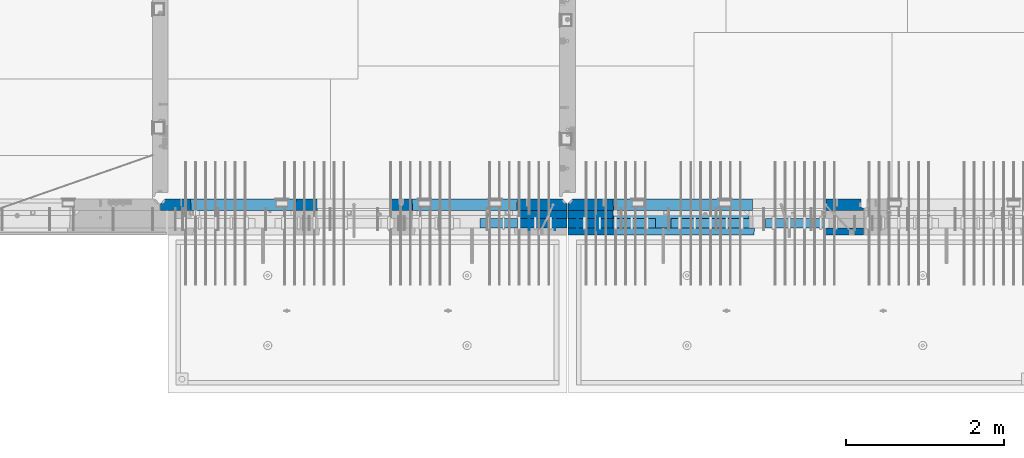
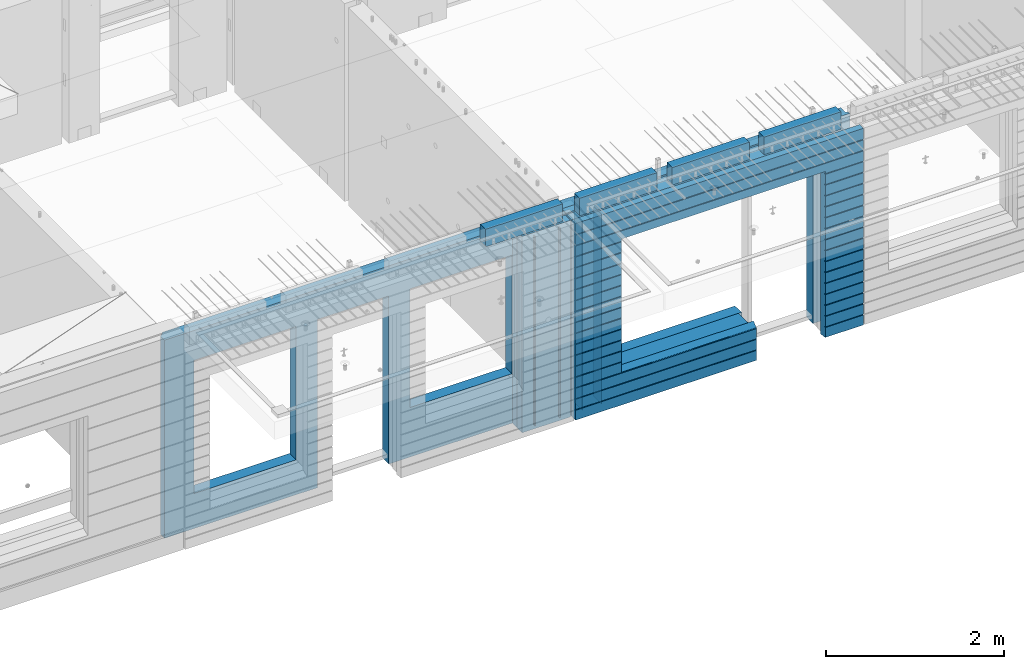
# One storey, part 232 of 350: 16 walls, 8 elements without a shape of their own.
"""IFC2X3 building model written with IfcOpenShell, lengths in millimetres."""

from ifc_helpers import new_model, si_unit, frame, origin_with_axes, place, context, subcontext, project, spatial, faceted_brep, material, type_object, element, aggregate, save


model = new_model("IFC2X3")

# Units and contexts
model_context = context("Model", 3, precision=1e-05, world=origin_with_axes())
body_context = subcontext(model_context, "Body", "Model", "MODEL_VIEW")
ifc_project = project(units=[si_unit("LENGTHUNIT", "METRE", prefix="MILLI"), si_unit("AREAUNIT", "SQUARE_METRE"), si_unit("VOLUMEUNIT", "CUBIC_METRE"), si_unit("MASSUNIT", "GRAM", prefix="KILO"), si_unit("TIMEUNIT", "SECOND"), si_unit("PLANEANGLEUNIT", "RADIAN"), si_unit("SOLIDANGLEUNIT", "STERADIAN"), si_unit("THERMODYNAMICTEMPERATUREUNIT", "DEGREE_CELSIUS"), si_unit("LUMINOUSINTENSITYUNIT", "LUMEN")], contexts=[model_context])

# Site, building, storey
site_placement = place(None, origin_with_axes())
site = spatial("IfcSite", under=ifc_project, at=site_placement, CompositionType="ELEMENT")
building_placement = place(site_placement, origin_with_axes())
building = spatial("IfcBuilding", under=site, at=building_placement, CompositionType="ELEMENT")
storey_placement = place(building_placement, origin_with_axes())
storey = spatial("IfcBuildingStorey", under=building, at=storey_placement, Name="2", CompositionType="ELEMENT", Elevation=0.0)

# Assembly, walls
assembly_1_placement = place(storey_placement, origin_with_axes())
assembly_1 = element("IfcElementAssembly", 1, at=assembly_1_placement, inside=storey, AssemblyPlace="NOTDEFINED", PredefinedType="REINFORCEMENT_UNIT")
ifc_material_1 = material(Name="Undefined")
wall_type_1 = type_object("IfcWallType", PredefinedType="NOTDEFINED")
wall_1_placement = place(assembly_1_placement, frame((21325.0, 7780.0, 86115.0), z_axis=(0.0, 0.0, 1.0), x_axis=(0.0, -1.0, 0.0)))
wall_1 = element("IfcWall", 2, at=wall_1_placement, type_object=wall_type_1, material=ifc_material_1, Name="(PD)", context=body_context, shape_type="Brep", body=[
    faceted_brep([(0.0, 5.0, -1300.0), (0.0, 5.0, 1300.0), (180.0, 5.0, 1300.0), (180.0, 5.0, -1300.0), (0.0, -5.0, 1300.0), (180.0, -5.0, 1300.0), (0.0, -5.0, -1300.0), (180.0, -5.0, -1300.0)], [[[0, 1, 2, 3]], [[1, 4, 5, 2]], [[4, 6, 7, 5]], [[6, 0, 3, 7]], [[5, 7, 3, 2]], [[6, 4, 1, 0]]]),
])
wall_2_placement = place(assembly_1_placement, frame((21650.0, 7780.0, 86115.0), z_axis=(0.0, 0.0, 1.0), x_axis=(0.0, -1.0, 0.0)))
wall_2 = element("IfcWall", 3, at=wall_2_placement, type_object=wall_type_1, material=ifc_material_1, Name="(PD)", context=body_context, shape_type="Brep", body=[
    faceted_brep([(0.0, 5.0, -1300.0), (0.0, 5.0, 1300.0), (180.0, 5.0, 1300.0), (180.0, 5.0, -1300.0), (0.0, -5.0, 1300.0), (180.0, -5.0, 1300.0), (0.0, -5.0, -1300.0), (180.0, -5.0, -1300.0)], [[[0, 1, 2, 3]], [[1, 4, 5, 2]], [[4, 6, 7, 5]], [[6, 0, 3, 7]], [[5, 7, 3, 2]], [[6, 4, 1, 0]]]),
])

assembly_2_placement = place(storey_placement, origin_with_axes())
assembly_2 = element("IfcElementAssembly", 4, at=assembly_2_placement, inside=storey, AssemblyPlace="NOTDEFINED", PredefinedType="REINFORCEMENT_UNIT")
wall_3_placement = place(assembly_2_placement, frame((22190.0, 7780.0, 86115.0), z_axis=(0.0, 0.0, 1.0), x_axis=(0.0, -1.0, 0.0)))
wall_3 = element("IfcWall", 5, at=wall_3_placement, type_object=wall_type_1, material=ifc_material_1, Name="(PD)", context=body_context, shape_type="Brep", body=[
    faceted_brep([(0.0, 5.0, -1300.0), (0.0, 5.0, 1300.0), (180.0, 5.0, 1300.0), (180.0, 5.0, -1300.0), (0.0, -5.0, 1300.0), (180.0, -5.0, 1300.0), (0.0, -5.0, -1300.0), (180.0, -5.0, -1300.0)], [[[0, 1, 2, 3]], [[1, 4, 5, 2]], [[4, 6, 7, 5]], [[6, 0, 3, 7]], [[5, 7, 3, 2]], [[6, 4, 1, 0]]]),
])
wall_4_placement = place(assembly_2_placement, frame((21940.0, 7780.0, 86115.0), z_axis=(0.0, 0.0, 1.0), x_axis=(0.0, -1.0, 0.0)))
wall_4 = element("IfcWall", 6, at=wall_4_placement, type_object=wall_type_1, material=ifc_material_1, Name="(PD)", context=body_context, shape_type="Brep", body=[
    faceted_brep([(0.0, 5.0, -1300.0), (0.0, 5.0, 1300.0), (180.0, 5.0, 1300.0), (180.0, 5.0, -1300.0), (0.0, -5.0, 1300.0), (180.0, -5.0, 1300.0), (0.0, -5.0, -1300.0), (180.0, -5.0, -1300.0)], [[[0, 1, 2, 3]], [[1, 4, 5, 2]], [[4, 6, 7, 5]], [[6, 0, 3, 7]], [[5, 7, 3, 2]], [[6, 4, 1, 0]]]),
])

# Assemblies, wall
assembly_3_placement = place(storey_placement, origin_with_axes())
assembly_3 = element("IfcElementAssembly", 7, at=assembly_3_placement, inside=storey, AssemblyPlace="NOTDEFINED", PredefinedType="REINFORCEMENT_UNIT")
assembly_4_placement = place(assembly_3_placement, origin_with_axes())
assembly_4 = element("IfcElementAssembly", 8, at=assembly_4_placement, Name="Steel Assembly", AssemblyPlace="NOTDEFINED", PredefinedType="NOTDEFINED")
aggregate(assembly_3, [assembly_4])
ifc_material_2 = material()
wall_type_2 = type_object("IfcWallType", PredefinedType="NOTDEFINED")
wall_5_placement = place(assembly_4_placement, frame((20699.9998568133, 7690.00021946163, 87590.0), z_axis=(0.0, 0.0, 1.0), x_axis=(1.0, 0.0, 0.0)))
wall_5 = element("IfcWall", 9, at=wall_5_placement, type_object=wall_type_2, material=ifc_material_2, context=body_context, shape_type="Brep", body=[
    faceted_brep([(0.0, 60.0, -120.0), (0.0, 60.0, 120.0), (1000.0, 60.0, 120.0), (1000.0, 60.0, -120.0), (0.0, -60.0, 120.0), (1000.0, -60.0, 120.0), (0.0, -60.0, -120.0), (1000.0, -60.0, -120.0)], [[[0, 1, 2, 3]], [[1, 4, 5, 2]], [[4, 6, 7, 5]], [[6, 0, 3, 7]], [[5, 7, 3, 2]], [[6, 4, 1, 0]]]),
])
aggregate(assembly_4, [wall_5])

# Assemblies, walls
assembly_5_placement = place(storey_placement, origin_with_axes())
assembly_5 = element("IfcElementAssembly", 10, at=assembly_5_placement, inside=storey, AssemblyPlace="NOTDEFINED", PredefinedType="REINFORCEMENT_UNIT")
assembly_6_placement = place(assembly_5_placement, origin_with_axes())
assembly_6 = element("IfcElementAssembly", 11, at=assembly_6_placement, Name="Steel Assembly", AssemblyPlace="NOTDEFINED", PredefinedType="NOTDEFINED")
wall_6_placement = place(assembly_6_placement, frame((24309.9998568133, 7690.00021946163, 87590.0), z_axis=(0.0, 0.0, 1.0), x_axis=(1.0, 0.0, 0.0)))
wall_6 = element("IfcWall", 12, at=wall_6_placement, type_object=wall_type_2, material=ifc_material_2, context=body_context, shape_type="Brep", body=[
    faceted_brep([(0.0, 60.0, -120.0), (0.0, 60.0, 120.0), (1000.0, 60.0, 120.0), (1000.0, 60.0, -120.0), (0.0, -60.0, 120.0), (1000.0, -60.0, 120.0), (0.0, -60.0, -120.0), (1000.0, -60.0, -120.0)], [[[0, 1, 2, 3]], [[1, 4, 5, 2]], [[4, 6, 7, 5]], [[6, 0, 3, 7]], [[5, 7, 3, 2]], [[6, 4, 1, 0]]]),
])
aggregate(assembly_6, [wall_6])
assembly_7_placement = place(assembly_5_placement, origin_with_axes())
assembly_7 = element("IfcElementAssembly", 13, at=assembly_7_placement, Name="Steel Assembly", AssemblyPlace="NOTDEFINED", PredefinedType="NOTDEFINED")
wall_7_placement = place(assembly_7_placement, frame((23119.9998568133, 7690.00021946163, 87590.0), z_axis=(0.0, 0.0, 1.0), x_axis=(1.0, 0.0, 0.0)))
wall_7 = element("IfcWall", 14, at=wall_7_placement, type_object=wall_type_2, material=ifc_material_2, context=body_context, shape_type="Brep", body=[
    faceted_brep([(0.0, 60.0, -120.0), (0.0, 60.0, 120.0), (1000.0, 60.0, 120.0), (1000.0, 60.0, -120.0), (0.0, -60.0, 120.0), (1000.0, -60.0, 120.0), (0.0, -60.0, -120.0), (1000.0, -60.0, -120.0)], [[[0, 1, 2, 3]], [[1, 4, 5, 2]], [[4, 6, 7, 5]], [[6, 0, 3, 7]], [[5, 7, 3, 2]], [[6, 4, 1, 0]]]),
])
aggregate(assembly_7, [wall_7])
assembly_8_placement = place(assembly_5_placement, origin_with_axes())
assembly_8 = element("IfcElementAssembly", 15, at=assembly_8_placement, Name="Steel Assembly", AssemblyPlace="NOTDEFINED", PredefinedType="NOTDEFINED")
aggregate(assembly_5, [assembly_8, assembly_7, assembly_6])
wall_8_placement = place(assembly_8_placement, frame((21919.9998568133, 7690.00021946163, 87590.0), z_axis=(0.0, 0.0, 1.0), x_axis=(1.0, 0.0, 0.0)))
wall_8 = element("IfcWall", 16, at=wall_8_placement, type_object=wall_type_2, material=ifc_material_2, context=body_context, shape_type="Brep", body=[
    faceted_brep([(0.0, 60.0, -120.0), (0.0, 60.0, 120.0), (1000.0, 60.0, 120.0), (1000.0, 60.0, -120.0), (0.0, -60.0, 120.0), (1000.0, -60.0, 120.0), (0.0, -60.0, -120.0), (1000.0, -60.0, -120.0)], [[[0, 1, 2, 3]], [[1, 4, 5, 2]], [[4, 6, 7, 5]], [[6, 0, 3, 7]], [[5, 7, 3, 2]], [[6, 4, 1, 0]]]),
])
aggregate(assembly_8, [wall_8])

# Wall
ifc_material_3 = material(Name="CONCRETE/C35/45")
wall_type_3 = type_object("IfcWallType", PredefinedType="NOTDEFINED")
wall_9_placement = place(assembly_1_placement, frame((21810.0, 7925.0, 86112.5), z_axis=(0.0, 0.0, 1.0), x_axis=(-1.0, 3.00000001838171e-08, 0.0)))
wall_9 = element("IfcWall", 17, at=wall_9_placement, type_object=wall_type_3, material=ifc_material_3, context=body_context, shape_type="Brep", body=[
    faceted_brep([(5145.0, 75.0, -1357.5), (5145.0, -15.0, -1357.5), (5085.0, -75.0, -1357.5), (3165.00051719707, -75.0, -1357.5), (3161.15436335092, 75.0, -1357.5), (5085.0, -75.0, 1357.5), (5145.0, -15.0, 1357.5), (5145.0, 75.0, 1357.5), (10.0, 75.0, 1357.5), (10.0, -15.0, 1357.5), (70.0, -75.0, 1357.5), (10.0, -15.0, -1357.5), (70.0, -75.0, -1357.5), (10.0, 75.0, -1357.5), (2238.84667104322, 75.0, -1357.5), (2235.00051719707, -75.0, -1357.5), (2238.84667104322, 75.0, 948.653846153844), (2235.00051719707, -75.0, 952.5), (635.00013572734, -75.0, -682.5), (639.054189781393, 75.0, -678.445945945947), (639.054189781393, 75.0, 948.445945945947), (635.00013572734, -75.0, 952.5), (1965.00013572734, -75.0, -682.5), (1960.94608167329, 75.0, -678.445945945947), (1965.00013572734, -75.0, 952.5), (1960.94608167329, 75.0, 948.445945945947), (4764.99937278789, -75.0, -882.5), (4760.94531873383, 75.0, -878.445945945947), (3439.05342684194, 75.0, -878.445945945947), (3434.99937278789, -75.0, -882.5), (3165.00051719707, -75.0, 952.5), (3434.99937278789, -75.0, 952.5), (4764.99937278789, -75.0, 952.5), (4760.94531873383, 75.0, 948.445945945947), (3439.05342684194, 75.0, 948.445945945947), (3161.15436335092, 75.0, 948.653846153844)], [[[0, 1, 2, 3, 4]], [[5, 2, 1, 6]], [[0, 7, 6, 1]], [[5, 6, 7, 8, 9, 10]], [[9, 11, 12, 10]], [[8, 13, 11, 9]], [[12, 11, 13, 14, 15]], [[15, 14, 16, 17]], [[18, 19, 20, 21]], [[22, 23, 19, 18]], [[23, 22, 24, 25]], [[21, 20, 25, 24]], [[26, 27, 28, 29]], [[3, 2, 5, 10, 12, 15, 17, 30], [26, 29, 31, 32], [22, 18, 21, 24]], [[27, 26, 32, 33]], [[31, 34, 33, 32]], [[29, 28, 34, 31]], [[13, 8, 7, 0, 4, 35, 16, 14], [27, 33, 34, 28], [23, 25, 20, 19]], [[17, 16, 35, 30]], [[4, 3, 30, 35]]]),
])

wall_10_placement = place(assembly_2_placement, frame((25550.0, 7925.0, 86112.5), z_axis=(0.0, 0.0, 1.0), x_axis=(-1.0, 3.00000001838171e-08, 0.0)))
wall_10 = element("IfcWall", 18, at=wall_10_placement, type_object=wall_type_3, material=ifc_material_3, context=body_context, shape_type="Brep", body=[
    faceted_brep([(0.0, 75.0, 1357.5), (0.0, 75.0, -1357.5), (0.0, 45.0, -1357.5), (0.0, 45.0, 1357.5), (475.000517197066, -75.0, -1357.5), (478.846671043222, 75.0, -1357.5), (478.846671043219, 75.0, 948.653846153844), (475.000517197066, -75.0, 952.5), (32.5, -75.0, -1357.5), (32.5, 32.0, -1357.5), (32.5, -75.0, 1357.5), (32.5, 32.0, 1357.5), (3675.0, -75.0, 1357.5), (3735.0, -15.0, 1357.5), (3735.0, 75.0, 1357.5), (3735.0, 75.0, -1357.5), (3735.0, -15.0, -1357.5), (3675.0, -75.0, -1357.5), (1405.00051719707, -75.0, -1357.5), (1401.15436335091, 75.0, -1357.5), (1405.00051719707, -75.0, -882.5), (1401.15436335091, 75.0, -878.445945945947), (1334.05403802673, 75.0, 948.653846153844), (3160.9460816706, 75.0, -878.445945945947), (3160.9460816706, 75.0, 948.445945945947), (1401.15436335091, 75.0, 948.653846153844), (1330.00013572465, -75.0, 952.5), (1405.00051719707, -75.0, 952.5), (3165.00013572465, -75.0, -882.5), (3165.00013572465, -75.0, 952.5)], [[[0, 1, 2, 3]], [[4, 5, 6, 7]], [[8, 9, 2, 1, 5, 4]], [[10, 11, 9, 8]], [[3, 2, 9, 11]], [[10, 12, 13, 14, 0, 3, 11]], [[15, 14, 13, 16]], [[12, 17, 16, 13]], [[15, 16, 17, 18, 19]], [[19, 18, 20, 21]], [[22, 6, 5, 1, 0, 14, 15, 19, 21, 23, 24, 25]], [[26, 7, 6, 22, 25, 27]], [[28, 20, 18, 17, 12, 10, 8, 4, 7, 26, 27, 29]], [[25, 24, 29, 27]], [[23, 28, 29, 24]], [[21, 20, 28, 23]]]),
])

wall_type_4 = type_object("IfcWallType", PredefinedType="NOTDEFINED")
wall_11_placement = place(assembly_1_placement, frame((21800.0000381475, 7800.0, 86112.5), z_axis=(0.0, 0.0, 1.0), x_axis=(-1.0, 3.00000001838171e-08, 0.0)))
wall_11 = element("IfcWall", 19, at=wall_11_placement, type_object=wall_type_4, material=ifc_material_3, context=body_context, shape_type="Brep", body=[
    faceted_brep([(0.0, 50.0, -1357.5), (0.0, 50.0, 1357.5), (625.001908754726, 50.0, 1357.5), (625.001908754726, 50.0, -1357.5), (0.0, -50.0, 1357.5), (625.001908754726, -50.0, 1357.5), (0.0, -50.0, -1357.5), (625.001908754726, -50.0, -1357.5)], [[[0, 1, 2, 3]], [[1, 4, 5, 2]], [[4, 6, 7, 5]], [[6, 0, 3, 7]], [[5, 7, 3, 2]], [[6, 4, 1, 0]]]),
])

wall_12_placement = place(assembly_2_placement, frame((22385.0000381475, 7800.00011629906, 86112.5), z_axis=(0.0, 0.0, 1.0), x_axis=(-1.0, 3.00000001838171e-08, 0.0)))
wall_12 = element("IfcWall", 20, at=wall_12_placement, type_object=wall_type_4, material=ifc_material_3, context=body_context, shape_type="Brep", body=[
    faceted_brep([(0.0, 50.0, -1357.5), (0.0, 50.0, 1357.5), (570.001908754726, 50.0, 1357.5), (570.001908754726, 50.0, -1357.5), (0.0, -50.0, 1357.5), (570.001908754726, -50.0, 1357.5), (0.0, -50.0, -1357.5), (570.001908754726, -50.0, -1357.5)], [[[0, 1, 2, 3]], [[1, 4, 5, 2]], [[4, 6, 7, 5]], [[6, 0, 3, 7]], [[5, 7, 3, 2]], [[6, 4, 1, 0]]]),
])

ifc_material_4 = material(Name="SPU")
wall_type_5 = type_object("IfcWallType", PredefinedType="NOTDEFINED")
wall_13_placement = place(assembly_1_placement, frame((21800.0000381475, 7690.0, 86102.5), z_axis=(0.0, 0.0, 1.0), x_axis=(-1.0, 3.00000001838171e-08, 0.0)))
wall_13 = element("IfcWall", 21, at=wall_13_placement, type_object=wall_type_5, material=ifc_material_4, context=body_context, shape_type="Brep", body=[
    faceted_brep([(0.0, 60.0, -1347.5), (0.0, 60.0, 1347.5), (625.001908754726, 60.0, 1347.5), (625.001908754726, 60.0, -1347.5), (0.0, -60.0, 1347.5), (625.001908754726, -60.0, 1347.5), (0.0, -60.0, -1347.5), (625.001908754726, -60.0, -1347.5)], [[[0, 1, 2, 3]], [[1, 4, 5, 2]], [[4, 6, 7, 5]], [[6, 0, 3, 7]], [[5, 7, 3, 2]], [[6, 4, 1, 0]]]),
])

aggregate(assembly_1, [wall_13, wall_11, wall_1, wall_2, wall_9])

wall_14_placement = place(assembly_2_placement, frame((22385.0000381475, 7690.00011629906, 86102.5), z_axis=(0.0, 0.0, 1.0), x_axis=(-1.0, 3.00000001838171e-08, 0.0)))
wall_14 = element("IfcWall", 22, at=wall_14_placement, type_object=wall_type_5, material=ifc_material_4, context=body_context, shape_type="Brep", body=[
    faceted_brep([(0.0, 60.0, -1347.5), (0.0, 60.0, 1347.5), (570.001908754726, 60.0, 1347.5), (570.001908754726, 60.0, -1347.5), (0.0, -60.0, 1347.5), (570.001908754726, -60.0, 1347.5), (0.0, -60.0, -1347.5), (570.001908754726, -60.0, -1347.5)], [[[0, 1, 2, 3]], [[1, 4, 5, 2]], [[4, 6, 7, 5]], [[6, 0, 3, 7]], [[5, 7, 3, 2]], [[6, 4, 1, 0]]]),
])

ifc_material_5 = material(Name="CONCRETE/C30/37")
wall_type_6 = type_object("IfcWallType", PredefinedType="NOTDEFINED")
wall_15_placement = place(assembly_2_placement, frame((25550.0, 7587.5, 86102.5), z_axis=(0.0, 0.0, 1.0), x_axis=(-1.0, 3.00000001838171e-08, 0.0)))
wall_15 = element("IfcWall", 23, at=wall_15_placement, type_object=wall_type_6, material=ifc_material_5, context=body_context, shape_type="Brep", body=[
    faceted_brep([(3135.00013572465, 42.5, -912.000000055254), (3135.00013572465, 42.5, -912.5), (3134.8486205936, 41.2121213860491, -911.742424344731), (3735.0, 32.4999991126861, -1049.99999959956), (3735.0, 32.4999992506973, -1060.00000000076), (1383.82179161871, 32.4999992506973, -1060.00000000076), (1383.82179160247, 32.4999991126861, -1049.99999959956), (3735.0, 42.5, -1062.00000005522), (1384.99845837354, 42.5, -1062.00000005522), (3735.0, 42.5, -1198.00000011075), (1384.99845837354, 42.5, -1198.00000011075), (3735.0, 32.4999991121604, -1199.99999959957), (1383.8217916024, 32.4999991121604, -1199.99999959957), (3735.0, 32.4999992501671, -1210.00000000079), (1383.82179161864, 32.4999992501671, -1210.00000000079), (3735.0, 42.5, -1212.00000005524), (1384.99845837354, 42.5, -1212.00000005524), (3735.0, 42.5, -1347.5), (1384.99845837354, 42.5, -1347.5), (3735.0, -42.5, -1347.5), (1374.99679170687, -42.5, -1347.5), (3.63797880709171e-12, 32.4999992499725, 1039.99999999921), (3735.0, 32.4999992499725, 1039.99999999921), (3735.0, 42.5, 1037.99999994476), (0.0, 42.5, 1037.99999994476), (3.63797880709171e-12, 32.4999991119639, 1050.00000040043), (3735.0, 32.4999991119639, 1050.00000040043), (0.0, 42.5, 1051.99999988925), (3735.0, 42.5, 1051.99999988925), (0.0, 42.5, 1187.99999994476), (3735.0, 42.5, 1187.99999994476), (-3.63797880709171e-12, 32.499999249967, 1189.99999999923), (3735.0, 32.499999249967, 1189.99999999923), (-3.63797880709171e-12, 32.4999991119576, 1200.00000040043), (3735.0, 32.4999991119576, 1200.00000040043), (0.0, 42.5, 1201.99999988925), (3735.0, 42.5, 1201.99999988925), (0.0, 42.5, 1347.5), (3735.0, 42.5, 1347.5), (0.0, -42.5, 1347.5), (3735.0, -42.5, 1347.5), (3125.00013572465, -42.5, 927.5), (3125.00013572465, -42.5, -862.5), (1374.99679170687, -42.5, -862.5), (0.0, -42.5, -1347.5), (505.000125040202, -42.5, -1347.5), (505.000125040206, -42.5, 927.5), (505.000125040206, -42.5, 932.502857142856), (1370.00013572465, -42.5, 932.502857142856), (1374.99679170687, -42.5, 932.5), (3125.00013572465, -42.5, 932.5), (0.0, 42.5, -1347.5), (494.998458373539, 42.5, -1347.5), (0.0, 42.5, -1212.00000005524), (494.998458373539, 42.5, -1212.00000005524), (0.0, 32.4999992501671, -1210.00000000079), (496.175125128437, 32.4999992501671, -1210.00000000079), (0.0, 32.4999991121604, -1199.99999959957), (496.175125144673, 32.4999991121604, -1199.99999959957), (0.0, 42.5, -1198.00000011075), (494.998458373539, 42.5, -1198.00000011075), (0.0, 42.5, -1062.00000005522), (494.998458373539, 42.5, -1062.00000005522), (0.0, 32.4999992506973, -1060.00000000076), (496.175125128375, 32.4999992506973, -1060.00000000076), (0.0, 32.4999991126861, -1049.99999959956), (496.175125144611, 32.4999991126861, -1049.99999959956), (0.0, 42.5, -1048.00000011074), (494.998458373539, 42.5, -1048.00000011074), (0.0, 42.5, -912.000000055254), (494.998458373539, 42.5, -912.000000055254), (0.0, 32.4999992512376, -910.000000000786), (496.175125128309, 32.4999992512376, -910.000000000786), (0.0, 32.499999113239, -899.99999959959), (496.175125144546, 32.499999113239, -899.99999959959), (0.0, 42.5, -898.000000110769), (494.998458373539, 42.5, -898.000000110769), (0.0, 42.5, -762.000000055225), (494.998458373539, 42.5, -762.000000055225), (0.0, 32.4999992517696, -760.000000000757), (496.175125128244, 32.4999992517696, -760.000000000757), (0.0, 32.4999991137702, -749.99999959956), (496.175125144484, 32.4999991137702, -749.99999959956), (0.0, 42.5, -748.00000011074), (494.998458373539, 42.5, -748.00000011074), (0.0, 42.5, -612.000000055239), (494.998458373539, 42.5, -612.000000055239), (0.0, 32.4999992522971, -610.000000000771), (496.175125128182, 32.4999992522971, -610.000000000771), (0.0, 32.4999991143004, -599.99999959956), (496.175125144422, 32.4999991143004, -599.99999959956), (0.0, 42.5, -598.000000110755), (494.998458373539, 42.5, -598.000000110755), (0.0, 42.5, -462.000000055239), (494.998458373539, 42.5, -462.000000055239), (0.0, 32.4999992528365, -460.000000000771), (496.17512512812, 32.4999992528365, -460.000000000771), (0.0, 32.4999991148252, -449.999999599575), (496.17512514436, 32.4999991148252, -449.999999599575), (0.0, 42.5, -448.000000110755), (494.998458373539, 42.5, -448.000000110755), (0.0, 42.5, -312.000000055254), (494.998458373539, 42.5, -312.000000055254), (0.0, 32.4999992533649, -310.000000000786), (496.175125128058, 32.4999992533649, -310.000000000786), (0.0, 32.4999991153618, -299.99999959959), (496.175125144298, 32.4999991153618, -299.99999959959), (0.0, 42.5, -298.000000110769), (494.998458373539, 42.5, -298.000000110769), (0.0, 42.5, -162.000000055239), (494.998458373539, 42.5, -162.000000055239), (0.0, 32.4999992538978, -160.000000000757), (496.175125127997, 32.4999992538978, -160.000000000757), (0.0, 32.4999991158993, -149.99999959956), (496.175125144237, 32.4999991158993, -149.99999959956), (0.0, 42.5, -148.000000110755), (494.998458373539, 42.5, -148.000000110755), (0.0, 42.5, -12.0000000552391), (494.998458373539, 42.5, -12.0000000552391), (0.0, 32.4999992538942, -10.0000000007858), (496.175125127997, 32.4999992538942, -10.0000000007858), (3.63797880709171e-12, 32.4999992499852, 889.999999999229), (3.63797880709171e-12, 32.4999991119857, 900.000000400425), (496.175125144691, 32.4999991119857, 900.000000400425), (496.175125128459, 32.4999992499852, 889.999999999229), (0.0, 42.5, 887.999999944761), (494.998458373539, 42.5, 887.999999944761), (0.0, 42.5, 751.999999889245), (494.998458373539, 42.5, 751.999999889245), (0.0, 32.4999991120039, 750.00000040044), (496.175125144691, 32.4999991120039, 750.00000040044), (0.0, 32.4999992499997, 739.999999999229), (496.175125128455, 32.4999992499997, 739.999999999229), (0.0, 42.5, 737.999999944761), (494.998458373539, 42.5, 737.999999944761), (0.0, 42.5, 601.99999988926), (494.998458373539, 42.5, 601.99999988926), (0.0, 32.4999991120094, 600.00000040044), (496.175125144691, 32.4999991120094, 600.00000040044), (0.0, 32.499999250017, 589.999999999229), (496.175125128455, 32.499999250017, 589.999999999229), (0.0, 42.5, 587.999999944775), (494.998458373539, 42.5, 587.999999944775), (0.0, 42.5, 451.999999889231), (494.998458373539, 42.5, 451.999999889231), (0.0, 32.4999991120258, 450.000000400411), (496.175125144688, 32.4999991120258, 450.000000400411), (0.0, 32.4999992500289, 439.999999999214), (496.175125128451, 32.4999992500289, 439.999999999214), (0.0, 42.5, 437.999999944746), (494.998458373539, 42.5, 437.999999944746), (0.0, 42.5, 301.999999889245), (494.998458373539, 42.5, 301.999999889245), (-3.63797880709171e-12, 32.4999991120458, 300.00000040044), (496.175125144688, 32.4999991120458, 300.00000040044), (-3.63797880709171e-12, 32.4999992500416, 289.999999999229), (496.175125128451, 32.4999992500416, 289.999999999229), (0.0, 42.5, 287.999999944761), (494.998458373539, 42.5, 287.999999944761), (0.0, 42.5, 151.99999988926), (494.998458373539, 42.5, 151.99999988926), (0.0, 32.4999991120549, 150.00000040044), (496.175125144684, 32.4999991120549, 150.00000040044), (0.0, 32.4999992500552, 139.999999999229), (496.175125128448, 32.4999992500552, 139.999999999229), (0.0, 42.5, 137.999999944775), (494.998458373539, 42.5, 137.999999944775), (0.0, 42.5, 1.99999988924537), (494.998458373539, 42.5, 1.99999988924537), (0.0, 32.4999991158911, 4.00425051338971e-07), (496.175125144237, 32.4999991158911, 4.00425051338971e-07), (0.0, 42.5, 901.999999889245), (494.998458373539, 42.5, 901.999999889245), (494.998458373539, 42.5, 927.5), (505.000517197066, 42.5, 927.5), (1360.00013572465, 42.5, 927.5), (1370.00013572465, 42.5, 927.5), (1375.00051719707, 42.5, 927.5), (1384.99845837354, 42.5, 927.5), (3125.00013572465, 42.5, 927.5), (3135.00013572465, 42.5, 927.5), (3735.0, 42.5, 901.999999889245), (3135.00013572465, 42.5, 901.999999889245), (3735.0, 32.4999991119857, 900.000000400425), (3133.82366503195, 32.4999991119857, 900.000000400425), (3735.0, 32.4999992499852, 889.999999999229), (3133.82366504818, 32.4999992499852, 889.999999999229), (3735.0, 42.5, 887.999999944761), (3135.00013572465, 42.5, 887.999999944761), (3735.0, 42.5, 751.999999889245), (3135.00013572465, 42.5, 751.999999889245), (3735.0, 32.4999991120039, 750.00000040044), (3133.82366503195, 32.4999991120039, 750.00000040044), (3735.0, 32.4999992499997, 739.999999999229), (3133.82366504818, 32.4999992499997, 739.999999999229), (3735.0, 42.5, 737.999999944761), (3135.00013572465, 42.5, 737.999999944761), (3735.0, 42.5, 601.99999988926), (3135.00013572465, 42.5, 601.99999988926), (3735.0, 32.4999991120094, 600.00000040044), (3133.82366503195, 32.4999991120094, 600.00000040044), (3735.0, 32.499999250017, 589.999999999229), (3133.82366504818, 32.499999250017, 589.999999999229), (3735.0, 42.5, 587.999999944775), (3135.00013572465, 42.5, 587.999999944775), (3735.0, 42.5, 451.999999889231), (3135.00013572465, 42.5, 451.999999889231), (3735.0, 32.4999991120258, 450.000000400411), (3133.82366503195, 32.4999991120258, 450.000000400411), (3735.0, 32.4999992500289, 439.999999999214), (3133.82366504818, 32.4999992500289, 439.999999999214), (3735.0, 42.5, 437.999999944746), (3135.00013572465, 42.5, 437.999999944746), (3735.0, 42.5, 301.999999889245), (3135.00013572465, 42.5, 301.999999889245), (3735.0, 32.4999991120458, 300.00000040044), (3133.82366503195, 32.4999991120458, 300.00000040044), (3735.0, 32.4999992500416, 289.999999999229), (3133.82366504819, 32.4999992500416, 289.999999999229), (3735.0, 42.5, 287.999999944761), (3135.00013572465, 42.5, 287.999999944761), (3735.0, 42.5, 151.99999988926), (3135.00013572465, 42.5, 151.99999988926), (3735.0, 32.4999991120549, 150.00000040044), (3133.82366503195, 32.4999991120549, 150.00000040044), (3735.0, 32.4999992500552, 139.999999999229), (3133.82366504819, 32.4999992500552, 139.999999999229), (3735.0, 42.5, 137.999999944775), (3135.00013572465, 42.5, 137.999999944775), (3735.0, 42.5, 1.99999988924537), (3135.00013572465, 42.5, 1.99999988924537), (3735.0, 32.4999991158911, 4.00425051338971e-07), (3735.0, 32.4999992538942, -10.0000000007858), (3133.82366504864, 32.4999992538942, -10.0000000007858), (3133.8236650324, 32.4999991158911, 4.00425051338971e-07), (3735.0, 42.5, -12.0000000552391), (3135.00013572465, 42.5, -12.0000000552391), (3735.0, 42.5, -148.000000110755), (3135.00013572465, 42.5, -148.000000110755), (3735.0, 32.4999991158993, -149.99999959956), (3133.8236650324, 32.4999991158993, -149.99999959956), (3735.0, 32.4999992538978, -160.000000000757), (3133.82366504864, 32.4999992538978, -160.000000000757), (3735.0, 42.5, -162.000000055239), (3135.00013572465, 42.5, -162.000000055239), (3735.0, 42.5, -298.000000110769), (3135.00013572465, 42.5, -298.000000110769), (3735.0, 32.4999991153618, -299.99999959959), (3133.82366503234, 32.4999991153618, -299.99999959959), (3735.0, 32.4999992533649, -310.000000000786), (3133.82366504858, 32.4999992533649, -310.000000000786), (3735.0, 42.5, -312.000000055254), (3135.00013572465, 42.5, -312.000000055254), (3735.0, 42.5, -448.000000110755), (3135.00013572465, 42.5, -448.000000110755), (3735.0, 32.4999991148252, -449.999999599575), (3133.82366503228, 32.4999991148252, -449.999999599575), (3735.0, 32.4999992528365, -460.000000000771), (3133.82366504852, 32.4999992528365, -460.000000000771), (3735.0, 42.5, -462.000000055239), (3135.00013572465, 42.5, -462.000000055239), (3735.0, 42.5, -598.000000110755), (3135.00013572465, 42.5, -598.000000110755), (3735.0, 32.4999991143004, -599.99999959956), (3133.82366503222, 32.4999991143004, -599.99999959956), (3735.0, 32.4999992522971, -610.000000000771), (3133.82366504845, 32.4999992522971, -610.000000000771), (3735.0, 42.5, -612.000000055239), (3135.00013572465, 42.5, -612.000000055239), (3735.0, 42.5, -748.00000011074), (3135.00013572465, 42.5, -748.00000011074), (3735.0, 32.4999991137702, -749.99999959956), (3133.82366503216, 32.4999991137702, -749.99999959956), (3735.0, 32.4999992517696, -760.000000000757), (3133.82366504839, 32.4999992517696, -760.000000000757), (3735.0, 42.5, -762.000000055225), (3135.00013572465, 42.5, -762.000000055225), (3735.0, 42.5, -898.000000110769), (3135.00013572465, 42.5, -898.000000110769), (3735.0, 32.499999113239, -899.99999959959), (3133.82366503209, 32.499999113239, -899.99999959959), (3133.82366504284, 32.4999992045623, -906.617646590923), (3735.0, 42.5, -1048.00000011074), (3735.0, 42.5, -912.000000055254), (3735.0, 32.4999992512376, -910.000000000786), (1384.99845837354, 42.5, -1048.00000011074), (1384.99845837354, 42.5, -912.5), (1384.84691798997, 41.2121213860719, -911.742424344746), (1383.82179161877, 32.4999992512376, -910.000000000786), (1383.82179161327, 32.4999992045614, -906.617646590908)], [[[0, 1, 2]], [[3, 4, 5, 6]], [[4, 7, 8, 5]], [[7, 9, 10, 8]], [[9, 11, 12, 10]], [[11, 13, 14, 12]], [[13, 15, 16, 14]], [[15, 17, 18, 16]], [[17, 19, 20, 18]], [[21, 22, 23, 24]], [[25, 26, 22, 21]], [[27, 28, 26, 25]], [[28, 27, 29, 30]], [[31, 32, 30, 29]], [[33, 34, 32, 31]], [[35, 36, 34, 33]], [[37, 38, 36, 35]], [[37, 39, 40, 38]], [[41, 42, 43, 20, 19, 40, 39, 44, 45, 46, 47, 48, 49, 50]], [[44, 51, 52, 45]], [[51, 53, 54, 52]], [[53, 55, 56, 54]], [[55, 57, 58, 56]], [[57, 59, 60, 58]], [[59, 61, 62, 60]], [[61, 63, 64, 62]], [[63, 65, 66, 64]], [[65, 67, 68, 66]], [[67, 69, 70, 68]], [[69, 71, 72, 70]], [[71, 73, 74, 72]], [[73, 75, 76, 74]], [[75, 77, 78, 76]], [[77, 79, 80, 78]], [[79, 81, 82, 80]], [[81, 83, 84, 82]], [[83, 85, 86, 84]], [[85, 87, 88, 86]], [[87, 89, 90, 88]], [[89, 91, 92, 90]], [[91, 93, 94, 92]], [[93, 95, 96, 94]], [[95, 97, 98, 96]], [[97, 99, 100, 98]], [[99, 101, 102, 100]], [[101, 103, 104, 102]], [[103, 105, 106, 104]], [[105, 107, 108, 106]], [[107, 109, 110, 108]], [[109, 111, 112, 110]], [[111, 113, 114, 112]], [[113, 115, 116, 114]], [[115, 117, 118, 116]], [[117, 119, 120, 118]], [[121, 122, 123, 124]], [[125, 121, 124, 126]], [[127, 125, 126, 128]], [[129, 127, 128, 130]], [[131, 129, 130, 132]], [[133, 131, 132, 134]], [[135, 133, 134, 136]], [[137, 135, 136, 138]], [[139, 137, 138, 140]], [[141, 139, 140, 142]], [[143, 141, 142, 144]], [[145, 143, 144, 146]], [[147, 145, 146, 148]], [[149, 147, 148, 150]], [[151, 149, 150, 152]], [[153, 151, 152, 154]], [[155, 153, 154, 156]], [[157, 155, 156, 158]], [[159, 157, 158, 160]], [[161, 159, 160, 162]], [[163, 161, 162, 164]], [[165, 163, 164, 166]], [[167, 165, 166, 168]], [[169, 167, 168, 170]], [[119, 169, 170, 120]], [[117, 115, 113, 111, 109, 107, 105, 103, 101, 99, 97, 95, 93, 91, 89, 87, 85, 83, 81, 79, 77, 75, 73, 71, 69, 67, 65, 63, 61, 59, 57, 55, 53, 51, 44, 39, 37, 35, 33, 31, 29, 27, 25, 21, 24, 171, 122, 121, 125, 127, 129, 131, 133, 135, 137, 139, 141, 143, 145, 147, 149, 151, 153, 155, 157, 159, 161, 163, 165, 167, 169, 119]], [[122, 171, 172, 123]], [[173, 47, 46, 45, 52, 54, 56, 58, 60, 62, 64, 66, 68, 70, 72, 74, 76, 78, 80, 82, 84, 86, 88, 90, 92, 94, 96, 98, 100, 102, 104, 106, 108, 110, 112, 114, 116, 118, 120, 170, 168, 166, 164, 162, 160, 158, 156, 154, 152, 150, 148, 146, 144, 142, 140, 138, 136, 134, 132, 130, 128, 126, 124, 123, 172]], [[174, 175, 176, 177, 178, 49, 48, 47, 173]], [[49, 178, 179, 180, 50]], [[178, 177, 176, 175, 174, 173, 172, 171, 24, 23, 181, 182, 180, 179]], [[181, 183, 184, 182]], [[183, 185, 186, 184]], [[185, 187, 188, 186]], [[187, 189, 190, 188]], [[189, 191, 192, 190]], [[191, 193, 194, 192]], [[193, 195, 196, 194]], [[195, 197, 198, 196]], [[197, 199, 200, 198]], [[199, 201, 202, 200]], [[201, 203, 204, 202]], [[203, 205, 206, 204]], [[205, 207, 208, 206]], [[207, 209, 210, 208]], [[209, 211, 212, 210]], [[211, 213, 214, 212]], [[213, 215, 216, 214]], [[215, 217, 218, 216]], [[217, 219, 220, 218]], [[219, 221, 222, 220]], [[221, 223, 224, 222]], [[223, 225, 226, 224]], [[225, 227, 228, 226]], [[227, 229, 230, 228]], [[231, 232, 233, 234]], [[232, 235, 236, 233]], [[235, 237, 238, 236]], [[237, 239, 240, 238]], [[239, 241, 242, 240]], [[241, 243, 244, 242]], [[243, 245, 246, 244]], [[245, 247, 248, 246]], [[247, 249, 250, 248]], [[249, 251, 252, 250]], [[251, 253, 254, 252]], [[253, 255, 256, 254]], [[255, 257, 258, 256]], [[257, 259, 260, 258]], [[259, 261, 262, 260]], [[261, 263, 264, 262]], [[263, 265, 266, 264]], [[265, 267, 268, 266]], [[267, 269, 270, 268]], [[269, 271, 272, 270]], [[271, 273, 274, 272]], [[273, 275, 276, 274]], [[275, 277, 278, 276]], [[277, 279, 280, 278]], [[41, 50, 180, 182, 184, 186, 188, 190, 192, 194, 196, 198, 200, 202, 204, 206, 208, 210, 212, 214, 216, 218, 220, 222, 224, 226, 228, 230, 234, 233, 236, 238, 240, 242, 244, 246, 248, 250, 252, 254, 256, 258, 260, 262, 264, 266, 268, 270, 272, 274, 276, 278, 280, 281, 42]], [[229, 231, 234, 230]], [[227, 225, 223, 221, 219, 217, 215, 213, 211, 209, 207, 205, 203, 201, 199, 197, 195, 193, 191, 189, 187, 185, 183, 181, 23, 22, 26, 28, 30, 32, 34, 36, 38, 40, 19, 17, 15, 13, 11, 9, 7, 4, 3, 282, 283, 284, 279, 277, 275, 273, 271, 269, 267, 265, 263, 261, 259, 257, 255, 253, 251, 249, 247, 245, 243, 241, 239, 237, 235, 232, 231, 229]], [[0, 283, 282, 285, 286, 1]], [[287, 2, 1, 286]], [[288, 284, 283, 0, 2, 287]], [[280, 279, 284, 288, 289, 281]], [[43, 42, 281, 289]], [[288, 287, 286, 285, 6, 5, 8, 10, 12, 14, 16, 18, 20, 43, 289]], [[282, 3, 6, 285]]]),
])

ifc_material_6 = material(Name="COS5gt")
wall_type_7 = type_object("IfcWallType", PredefinedType="NOTDEFINED")
wall_16_placement = place(assembly_2_placement, frame((25075.0, 7740.0, 86102.5), z_axis=(0.0, 0.0, 1.0), x_axis=(-1.0, 3.00000001838171e-08, 0.0)))
wall_16 = element("IfcWall", 24, at=wall_16_placement, type_object=wall_type_7, material=ifc_material_6, context=body_context, shape_type="Brep", body=[
    faceted_brep([(970.000517197066, -40.0, -1347.5), (1040.00013572734, -110.0, -1347.5), (1040.00013572734, -110.0, -872.5), (970.00013572734, -40.0, -872.5), (970.00013572734, -110.0, -872.5), (2690.0, 90.0, -1297.5), (2690.0, 90.0, -1347.5), (970.000517197066, 90.0, -1347.5), (970.000517197066, 90.0, -1297.5), (2690.0, 110.0, -1297.5), (970.000517197066, 110.0, -1297.5), (2690.0, 110.0, 1347.5), (2690.0, -110.0, 1347.5), (2690.0, -110.0, -1347.5), (0.0, 110.0, 1347.5), (0.0, -110.0, 1347.5), (0.0, 110.0, 1002.5), (0.0, -110.0, 1002.5), (970.000517197066, 110.0, 1002.5), (970.000517197066, -110.0, 1002.5), (970.000517197066, 110.0, 952.5), (970.000517197066, -110.0, 958.445945945947), (2680.00013572465, 110.0, -857.5), (2680.00013572465, 110.0, -862.5), (2685.9460816706, -110.000000000001, -868.445945945947), (2685.9460816706, -110.0, 958.445945945947), (2680.00013572465, 110.0, 952.5), (970.000517197066, 110.0, -862.5), (2650.00013572465, 110.0, -862.5), (970.000517197066, -110.0, -868.445945945947)], [[[0, 1, 2, 3]], [[4, 3, 2]], [[5, 6, 7, 8]], [[9, 5, 8, 10]], [[11, 12, 13, 6, 5, 9]], [[14, 15, 12, 11]], [[15, 14, 16, 17]], [[17, 16, 18, 19]], [[19, 18, 20, 21]], [[22, 23, 24, 25, 26]], [[21, 20, 26, 25]], [[18, 16, 14, 11, 9, 10, 27, 28, 23, 22, 26, 20]], [[29, 24, 23, 28, 27]], [[1, 13, 12, 15, 17, 19, 21, 25, 24, 29, 4, 2]], [[7, 6, 13, 1, 0]], [[29, 27, 10, 8, 7, 0, 3, 4]]]),
])

aggregate(assembly_2, [wall_14, wall_12, wall_3, wall_4, wall_15, wall_16, wall_10])

save(model, "model.ifc")
